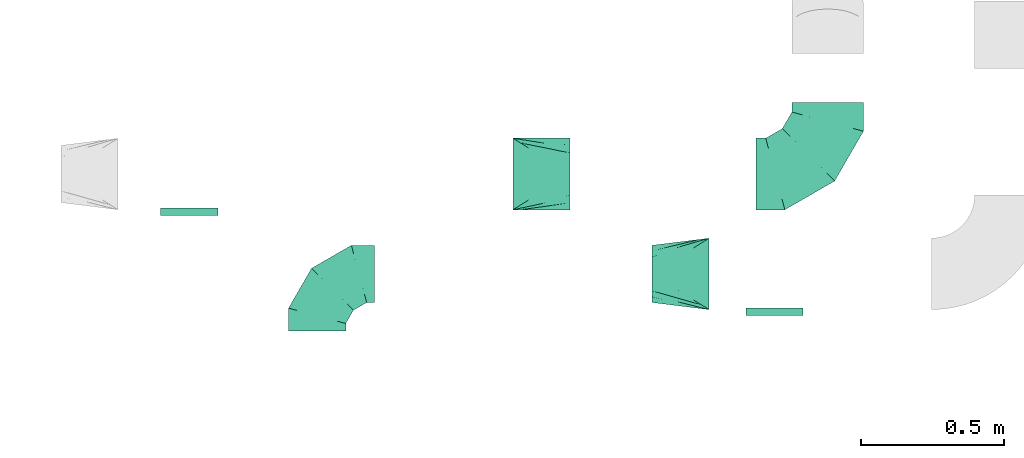
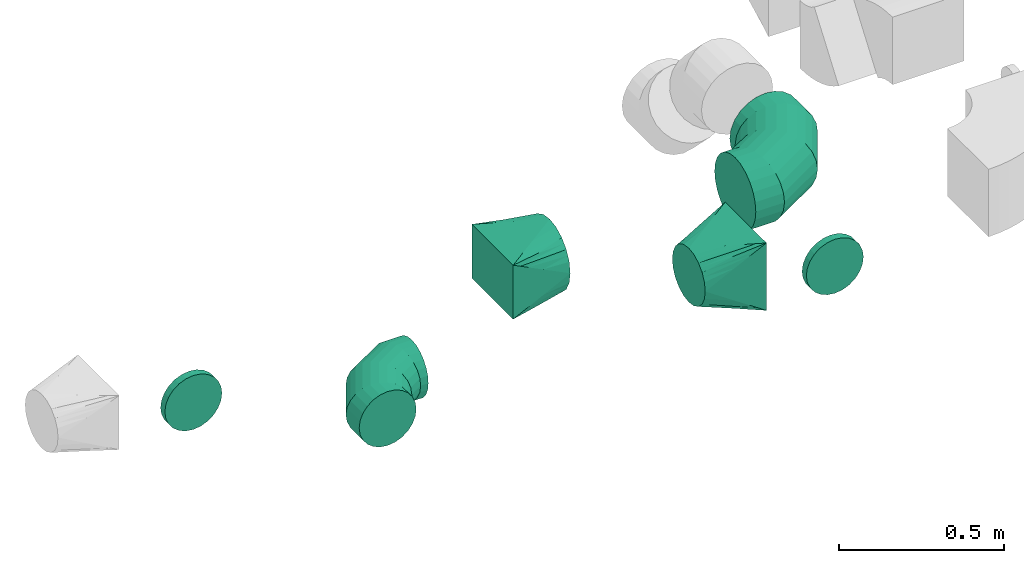
# One storey, part 8 of 44: 6 flow fittings.
"""IFC2X3 building model written with IfcOpenShell, lengths in millimetres."""

import ifcopenshell
import ifcopenshell.guid

model = None  # the IFC model being written
_history = None  # IfcOwnerHistory: only IFC2X3 demands one
_inside = {}  # id of a spatial element -> (the spatial element, [elements in it])
_under = {}  # id of a project, library or spatial element -> (it, [spatial elements below it])
_declared = {}  # id of a project -> (the project, [libraries it declares])
_typed = {}  # id of a type object -> (the type object, [elements of that type])
_made_of = {}  # id of a material, layer set ... -> (it, [elements and type objects made of it])


def new_model(schema):
    """Start an empty IFC model of exactly this schema.

    Asked for "IFC4X3", IfcOpenShell would pick the latest addendum, in which some entities
    have other attributes; the version numbers below select the first issue.
    IFC2X3 requires an IfcOwnerHistory on every rooted entity: one is made here for all.
    """
    global model, _history
    if schema == "IFC4X3":
        model = ifcopenshell.file(schema_version=(4, 3, 0, 0))
    else:
        model = ifcopenshell.file(schema=schema)
    _inside.clear()
    _under.clear()
    _declared.clear()
    _typed.clear()
    _made_of.clear()
    _history = None
    if model.schema == "IFC2X3":
        org = make("IfcOrganization", Name="unknown")
        user = make(
            "IfcPersonAndOrganization",
            ThePerson=make("IfcPerson", FamilyName="unknown"),
            TheOrganization=org,
        )
        app = make(
            "IfcApplication",
            ApplicationDeveloper=org,
            Version="unknown",
            ApplicationFullName="unknown",
            ApplicationIdentifier="unknown",
        )
        _history = make(
            "IfcOwnerHistory",
            OwningUser=user,
            OwningApplication=app,
            ChangeAction="ADDED",
            CreationDate=0,
        )
    return model


def make(cls, **values):
    """One entity of the class cls with the attributes given. An attribute that is None is left unset."""
    return model.create_entity(
        cls, **{name: value for name, value in values.items() if value is not None}
    )


def entity(cls, *values):
    """Any entity or typed value of the class cls, its attributes in the order of the schema. None: left unset."""
    e = model.create_entity(cls)
    for i, value in enumerate(values):
        if value is not None:
            e[i] = value
    return e


def rooted(cls, **values):
    """An entity with a GlobalId (a new one), such as an element, a storey or a relation."""
    return make(cls, GlobalId=ifcopenshell.guid.new(), OwnerHistory=_history, **values)


def si_unit(unit_type, name, prefix=None):
    """IfcSIUnit, for example si_unit("LENGTHUNIT", "METRE", prefix="MILLI")."""
    return make("IfcSIUnit", UnitType=unit_type, Prefix=prefix, Name=name)


def converted_unit(unit_type, name, factor, base, dimensions=None, offset=None):
    """IfcConversionBasedUnit, such as the inch: factor (a typed value) times the base unit."""
    return make(
        "IfcConversionBasedUnit"
        if offset is None
        else "IfcConversionBasedUnitWithOffset",
        ConversionOffset=offset,
        Dimensions=None
        if dimensions is None
        else entity("IfcDimensionalExponents", *dimensions),
        UnitType=unit_type,
        Name=name,
        ConversionFactor=make(
            "IfcMeasureWithUnit", ValueComponent=factor, UnitComponent=base
        ),
    )


def derived_unit(unit_type, elements):
    """IfcDerivedUnit: a product of units, each with its exponent."""
    return make(
        "IfcDerivedUnit",
        Elements=[
            make("IfcDerivedUnitElement", Unit=unit, Exponent=power)
            for unit, power in elements
        ],
        UnitType=unit_type,
    )


def assignment(units):
    """IfcUnitAssignment: the units of a project."""
    return None if units is None else make("IfcUnitAssignment", Units=units)


def point(xyz):
    """IfcCartesianPoint."""
    return None if xyz is None else make("IfcCartesianPoint", Coordinates=xyz)


def direction(xyz):
    """IfcDirection."""
    return None if xyz is None else make("IfcDirection", DirectionRatios=xyz)


def frame(location, z_axis=None, x_axis=None):
    """IfcAxis2Placement3D, a coordinate frame: its origin and axes. An axis left out is left unset."""
    return make(
        "IfcAxis2Placement3D",
        Location=point(location),
        Axis=direction(z_axis),
        RefDirection=direction(x_axis),
    )


def origin():
    """The frame at (0, 0, 0) with its axes left unset."""
    return frame((0.0, 0.0, 0.0))


def place(relative_to, where):
    """IfcLocalPlacement: puts the frame where relative to a parent placement (None: the world)."""
    return make(
        "IfcLocalPlacement", PlacementRelTo=relative_to, RelativePlacement=where
    )


def context(
    kind, dimensions, precision=None, world=None, true_north=None, identifier=None
):
    """IfcGeometricRepresentationContext, for example the 3D "Model" context."""
    return make(
        "IfcGeometricRepresentationContext",
        ContextIdentifier=identifier,
        ContextType=kind,
        CoordinateSpaceDimension=dimensions,
        Precision=precision,
        WorldCoordinateSystem=world,
        TrueNorth=true_north,
    )


def subcontext(parent, identifier, kind, view, scale=None):
    """IfcGeometricRepresentationSubContext, for example "Body" below "Model"."""
    return make(
        "IfcGeometricRepresentationSubContext",
        ContextIdentifier=identifier,
        ContextType=kind,
        ParentContext=parent,
        TargetScale=scale,
        TargetView=view,
    )


def project(units=None, contexts=None):
    """IfcProject with its units and contexts."""
    return rooted(
        "IfcProject",
        Name="project",
        RepresentationContexts=contexts,
        UnitsInContext=assignment(units),
    )


def spatial(cls, under=None, at=None, **own):
    """A site, building, storey or space (cls), placed at a placement, below another one or the project."""
    s = rooted(cls, ObjectPlacement=at, **own)
    if under is not None:
        _under.setdefault(under.id(), (under, []))[1].append(s)
    return s


def faces_of(points, faces, orient=None, outer=None):
    """IfcFace entities. A face is a list of loops; a loop is a list of indices into points, from 0.

    orient and outer hold one flag for each loop. By default every Orientation is true, the
    first loop of a face is its IfcFaceOuterBound and the others are IfcFaceBound.
    """
    made = []
    for i, loops in enumerate(faces):
        bounds = []
        for j, loop in enumerate(loops):
            is_outer = j == 0 if outer is None else outer[i][j]
            bounds.append(
                make(
                    "IfcFaceOuterBound" if is_outer else "IfcFaceBound",
                    Bound=make("IfcPolyLoop", Polygon=[points[k] for k in loop]),
                    Orientation=True if orient is None else orient[i][j],
                )
            )
        made.append(make("IfcFace", Bounds=bounds))
    return made


def faceted_brep(points, faces, orient=None, outer=None, voids=None):
    """IfcFacetedBrep: a solid bounded by flat faces; with voids (closed shells), ...WithVoids."""
    shared = [point(p) for p in points]
    hull = make("IfcClosedShell", CfsFaces=faces_of(shared, faces, orient, outer))
    if voids is None:
        return make("IfcFacetedBrep", Outer=hull)
    return make(
        "IfcFacetedBrepWithVoids",
        Outer=hull,
        Voids=[
            make(cls, CfsFaces=faces_of(shared, fs, o, b)) for cls, fs, o, b in voids
        ],
    )


def shape(context_of_items, identifier, shape_type, items):
    """IfcShapeRepresentation: the items that make up one representation, for example the "Body"."""
    return make(
        "IfcShapeRepresentation",
        ContextOfItems=context_of_items,
        RepresentationIdentifier=identifier,
        RepresentationType=shape_type,
        Items=items,
    )


def source(mapping_origin, context_of_items, identifier, shape_type, items):
    """IfcRepresentationMap: a shape defined once, which mapped items show again and again."""
    return make(
        "IfcRepresentationMap",
        MappingOrigin=mapping_origin,
        MappedRepresentation=shape(context_of_items, identifier, shape_type, items),
    )


def transform(
    local_origin,
    x_axis=None,
    y_axis=None,
    z_axis=None,
    scale=None,
    scale2=None,
    scale3=None,
    uniform=True,
):
    """IfcCartesianTransformationOperator3D, or its non-uniform kind. x_axis, y_axis, z_axis: its Axis1, 2, 3."""
    if uniform:
        return make(
            "IfcCartesianTransformationOperator3D",
            Axis1=direction(x_axis),
            Axis2=direction(y_axis),
            LocalOrigin=point(local_origin),
            Scale=scale,
            Axis3=direction(z_axis),
        )
    return make(
        "IfcCartesianTransformationOperator3DnonUniform",
        Axis1=direction(x_axis),
        Axis2=direction(y_axis),
        LocalOrigin=point(local_origin),
        Scale=scale,
        Axis3=direction(z_axis),
        Scale2=scale2,
        Scale3=scale3,
    )


def mapped(mapping_source, mapping_target):
    """IfcMappedItem: shows the shape of a source again, moved by a transform."""
    return make(
        "IfcMappedItem", MappingSource=mapping_source, MappingTarget=mapping_target
    )


def material(Name=None, Category=None):
    """IfcMaterial."""
    return make("IfcMaterial", Name=Name, Category=Category)


def made_of(thing, what):
    """Note that an element or type object is made of a material, layer set ...; save() writes the relation."""
    if what is not None:
        _made_of.setdefault(what.id(), (what, []))[1].append(thing)
    return thing


def type_object(cls, material=None, **own):
    """A type object (cls), such as IfcWallType, which elements share."""
    return made_of(rooted(cls, **own), material)


def type_shapes(of_type, sources):
    """Give a type object the sources (RepresentationMaps) that its elements show as mapped items."""
    of_type.RepresentationMaps = sources


def element(
    cls,
    number,
    at=None,
    inside=None,
    cuts=None,
    type_object=None,
    material=None,
    context=None,
    identifier="Body",
    shape_type=None,
    held_by="IfcProductDefinitionShape",
    body=None,
    shapes=None,
    **own,
):
    """One element of the class cls, such as IfcWall. Its Tag is "e" and its number.

    at: its placement. inside: the storey or other place that contains it. cuts: it is an
    opening in that element (IfcRelVoidsElement). A single representation is given by context,
    identifier, shape_type and body (its items); several are given by shapes. held_by: the class
    of the entity that holds the representations. save() writes the other relations.
    """
    e = rooted(cls, Tag="e%d" % number, ObjectPlacement=at, **own)
    if body is not None:
        shapes = [shape(context, identifier, shape_type, body)]
    if shapes is not None:
        e.Representation = make(held_by, Representations=shapes)
    if inside is not None:
        _inside.setdefault(inside.id(), (inside, []))[1].append(e)
    if cuts is not None:
        rooted(
            "IfcRelVoidsElement", RelatingBuildingElement=cuts, RelatedOpeningElement=e
        )
    if type_object is not None:
        _typed.setdefault(type_object.id(), (type_object, []))[1].append(e)
    return made_of(e, material)


def aggregate(whole, parts):
    """IfcRelAggregates: a whole, such as a stair, and the parts it consists of."""
    return rooted("IfcRelAggregates", RelatingObject=whole, RelatedObjects=parts)


def save(model, path):
    """Write the relations noted so far, then the file.

    IfcRelAggregates (storeys below a building ...), IfcRelContainedInSpatialStructure (elements
    in a storey), IfcRelDefinesByType, IfcRelAssociatesMaterial and IfcRelDeclares: one each for
    every whole, place, type object, material and project.
    """
    for whole, parts in _under.values():
        aggregate(whole, parts)
    for where, things in _inside.values():
        rooted(
            "IfcRelContainedInSpatialStructure",
            RelatedElements=things,
            RelatingStructure=where,
        )
    for kind, things in _typed.values():
        rooted("IfcRelDefinesByType", RelatedObjects=things, RelatingType=kind)
    for what, things in _made_of.values():
        rooted("IfcRelAssociatesMaterial", RelatedObjects=things, RelatingMaterial=what)
    for by, libraries in _declared.values():
        rooted("IfcRelDeclares", RelatingContext=by, RelatedDefinitions=libraries)
    model.write(path)


model = new_model("IFC2X3")

# Units and contexts
model_context = context("Model", 3, precision=0.01, world=origin(), true_north=direction((6.12303176911189e-17, 1.0)))
body_context = subcontext(model_context, "Body", "Model", "MODEL_VIEW")
ifc_project = project(units=[si_unit("LENGTHUNIT", "METRE", prefix="MILLI"), si_unit("AREAUNIT", "SQUARE_METRE"), si_unit("VOLUMEUNIT", "CUBIC_METRE"), converted_unit("PLANEANGLEUNIT", "DEGREE", entity("IfcRatioMeasure", 0.0174532925199433), si_unit("PLANEANGLEUNIT", "RADIAN"), dimensions=[0, 0, 0, 0, 0, 0, 0]), si_unit("MASSUNIT", "GRAM", prefix="KILO"), derived_unit("MASSDENSITYUNIT", [(si_unit("MASSUNIT", "GRAM", prefix="KILO"), 1), (si_unit("LENGTHUNIT", "METRE"), -3)]), derived_unit("MOMENTOFINERTIAUNIT", [(si_unit("LENGTHUNIT", "METRE"), 4)]), si_unit("TIMEUNIT", "SECOND"), si_unit("FREQUENCYUNIT", "HERTZ"), si_unit("THERMODYNAMICTEMPERATUREUNIT", "DEGREE_CELSIUS"), derived_unit("THERMALTRANSMITTANCEUNIT", [(si_unit("MASSUNIT", "GRAM", prefix="KILO"), 1), (si_unit("THERMODYNAMICTEMPERATUREUNIT", "KELVIN"), -1), (si_unit("TIMEUNIT", "SECOND"), -3)]), derived_unit("VOLUMETRICFLOWRATEUNIT", [(si_unit("LENGTHUNIT", "METRE"), 3), (si_unit("TIMEUNIT", "SECOND"), -1)]), derived_unit("MASSFLOWRATEUNIT", [(si_unit("MASSUNIT", "GRAM", prefix="KILO"), 1), (si_unit("TIMEUNIT", "SECOND"), -1)]), derived_unit("ROTATIONALFREQUENCYUNIT", [(si_unit("TIMEUNIT", "SECOND"), -1)]), si_unit("ELECTRICCURRENTUNIT", "AMPERE"), si_unit("ELECTRICVOLTAGEUNIT", "VOLT"), si_unit("POWERUNIT", "WATT"), si_unit("FORCEUNIT", "NEWTON", prefix="KILO"), si_unit("ILLUMINANCEUNIT", "LUX"), si_unit("LUMINOUSFLUXUNIT", "LUMEN"), si_unit("LUMINOUSINTENSITYUNIT", "CANDELA"), derived_unit("USERDEFINED", [(si_unit("MASSUNIT", "GRAM", prefix="KILO"), -1), (si_unit("LENGTHUNIT", "METRE"), -2), (si_unit("TIMEUNIT", "SECOND"), 3), (si_unit("LUMINOUSFLUXUNIT", "LUMEN"), 1)]), derived_unit("LINEARVELOCITYUNIT", [(si_unit("LENGTHUNIT", "METRE"), 1), (si_unit("TIMEUNIT", "SECOND"), -1)]), si_unit("PRESSUREUNIT", "PASCAL"), derived_unit("USERDEFINED", [(si_unit("LENGTHUNIT", "METRE"), -2), (si_unit("MASSUNIT", "GRAM", prefix="KILO"), 1), (si_unit("TIMEUNIT", "SECOND"), -2)]), derived_unit("LINEARFORCEUNIT", [(si_unit("MASSUNIT", "GRAM", prefix="KILO"), 1), (si_unit("LENGTHUNIT", "METRE"), 1), (si_unit("TIMEUNIT", "SECOND"), -2), (si_unit("LENGTHUNIT", "METRE"), -1)]), derived_unit("PLANARFORCEUNIT", [(si_unit("MASSUNIT", "GRAM", prefix="KILO"), 1), (si_unit("LENGTHUNIT", "METRE"), 1), (si_unit("TIMEUNIT", "SECOND"), -2), (si_unit("LENGTHUNIT", "METRE"), -2)])], contexts=[model_context])

# Site, building, storey
site_placement = place(None, origin())
site = spatial("IfcSite", under=ifc_project, at=site_placement, CompositionType="ELEMENT")
building_placement = place(site_placement, origin())
building = spatial("IfcBuilding", under=site, at=building_placement, CompositionType="ELEMENT")
storey_placement = place(building_placement, frame((0.0, 0.0, 15900.0)))
storey = spatial("IfcBuildingStorey", under=building, at=storey_placement, CompositionType="ELEMENT", Elevation=15900.0)

# Flow fittings
ifc_material = material()
duct_fitting_type_1 = type_object("IfcDuctFittingType", PredefinedType="NOTDEFINED", material=ifc_material)
shared_shape_1 = source(origin(), body_context, "Body", "Brep", [
    faceted_brep([(-250.0, 0.0, -125.0), (-250.0, -32.35, -120.74), (-250.0, -62.5, -108.25), (-250.0, -88.39, -88.39), (-250.0, -108.25, -62.5), (-250.0, -120.74, -32.35), (-250.0, -125.0, 0.0), (-250.0, -120.74, 32.35), (-250.0, -108.25, 62.5), (-250.0, -88.39, 88.39), (-250.0, -62.5, 108.25), (-250.0, -32.35, 120.74), (-250.0, 0.0, 125.0), (-250.0, 32.35, 120.74), (-250.0, 62.5, 108.25), (-250.0, 88.39, 88.39), (-250.0, 108.25, 62.5), (-250.0, 120.74, 32.35), (-250.0, 125.0, 0.0), (-250.0, 120.74, -32.35), (-250.0, 108.25, -62.5), (-250.0, 88.39, -88.39), (-250.0, 62.5, -108.25), (-250.0, 32.35, -120.74), (-191.68, 32.35, 120.74), (-199.76, 62.5, 108.25), (-183.01, 0.0, 125.0), (-206.7, 88.39, 88.39), (-215.37, 120.74, 32.35), (-216.51, 125.0, 0.0), (-212.02, 108.25, 62.5), (-212.02, 108.25, -62.5), (-206.7, 88.39, -88.39), (-215.37, 120.74, -32.35), (-191.68, 32.35, -120.74), (-183.01, 0.0, -125.0), (-199.76, 62.5, -108.25), (-174.34, -32.35, -120.74), (-166.27, -62.5, -108.25), (-159.33, -88.39, -88.39), (-154.01, -108.25, -62.5), (-150.66, -120.74, -32.35), (-149.52, -125.0, 0.0), (-150.66, -120.74, 32.35), (-154.01, -108.25, 62.5), (-159.33, -88.39, 88.39), (-166.27, -62.5, 108.25), (-174.34, -32.35, 120.74), (-90.67, 90.67, 120.74), (-112.74, 112.74, 108.25), (-66.99, 66.99, 125.0), (-131.69, 131.69, 88.39), (-146.23, 146.23, 62.5), (-155.38, 155.38, 32.35), (-158.49, 158.49, 0.0), (-155.38, 155.38, -32.35), (-146.23, 146.23, -62.5), (-131.69, 131.69, -88.39), (-90.67, 90.67, -120.74), (-66.99, 66.99, -125.0), (-112.74, 112.74, -108.25), (-43.3, 43.3, -120.74), (-21.23, 21.23, -108.25), (-2.28, 2.28, -88.39), (12.26, -12.26, -62.5), (21.4, -21.4, -32.35), (24.52, -24.52, 0.0), (21.4, -21.4, 32.35), (12.26, -12.26, 62.5), (-2.28, 2.28, 88.39), (-21.23, 21.23, 108.25), (-43.3, 43.3, 120.74), (-32.35, 191.68, 120.74), (-62.5, 199.76, 108.25), (0.0, 183.01, 125.0), (-88.39, 206.7, 88.39), (-108.25, 212.02, 62.5), (-120.74, 215.37, 32.35), (-125.0, 216.51, 0.0), (-120.74, 215.37, -32.35), (-108.25, 212.02, -62.5), (-88.39, 206.7, -88.39), (-32.35, 191.68, -120.74), (0.0, 183.01, -125.0), (-62.5, 199.76, -108.25), (32.35, 174.34, -120.74), (62.5, 166.27, -108.25), (88.39, 159.33, -88.39), (108.25, 154.01, -62.5), (120.74, 150.66, -32.35), (125.0, 149.52, 0.0), (120.74, 150.66, 32.35), (108.25, 154.01, 62.5), (88.39, 159.33, 88.39), (62.5, 166.27, 108.25), (32.35, 174.34, 120.74), (-32.35, 250.0, -120.74), (-62.5, 250.0, -108.25), (-88.39, 250.0, -88.39), (-108.25, 250.0, -62.5), (-120.74, 250.0, -32.35), (-125.0, 250.0, 0.0), (-120.74, 250.0, 32.35), (-108.25, 250.0, 62.5), (-88.39, 250.0, 88.39), (-62.5, 250.0, 108.25), (-32.35, 250.0, 120.74), (0.0, 250.0, 125.0), (32.35, 250.0, 120.74), (62.5, 250.0, 108.25), (88.39, 250.0, 88.39), (108.25, 250.0, 62.5), (120.74, 250.0, 32.35), (125.0, 250.0, 0.0), (120.74, 250.0, -32.35), (108.25, 250.0, -62.5), (88.39, 250.0, -88.39), (62.5, 250.0, -108.25), (32.35, 250.0, -120.74), (0.0, 250.0, -125.0)], [[[0, 1, 2, 3, 4, 5, 6, 7, 8, 9, 10, 11, 12, 13, 14, 15, 16, 17, 18, 19, 20, 21, 22, 23]], [[24, 25, 14, 13]], [[26, 24, 13, 12]], [[14, 25, 27, 15]], [[28, 29, 18, 17]], [[30, 28, 17, 16]], [[15, 27, 30, 16]], [[20, 31, 32, 21]], [[33, 31, 20, 19]], [[18, 29, 33, 19]], [[34, 35, 0, 23]], [[36, 34, 23, 22]], [[21, 32, 36, 22]], [[1, 0, 35, 37]], [[2, 1, 37, 38]], [[38, 39, 3, 2]], [[5, 4, 40, 41]], [[6, 5, 41, 42]], [[39, 40, 4, 3]], [[6, 42, 43, 7]], [[7, 43, 44, 8]], [[8, 44, 45, 9]], [[9, 45, 46, 10]], [[10, 46, 47, 11]], [[26, 12, 11, 47]], [[48, 49, 25, 24]], [[50, 48, 24, 26]], [[27, 25, 49, 51]], [[52, 53, 28, 30]], [[51, 52, 30, 27]], [[29, 28, 53, 54]], [[55, 56, 31, 33]], [[54, 55, 33, 29]], [[32, 31, 56, 57]], [[58, 59, 35, 34]], [[60, 58, 34, 36]], [[57, 60, 36, 32]], [[37, 35, 59, 61]], [[38, 37, 61, 62]], [[39, 38, 62, 63]], [[41, 40, 64, 65]], [[42, 41, 65, 66]], [[63, 64, 40, 39]], [[43, 42, 66, 67]], [[44, 43, 67, 68]], [[68, 69, 45, 44]], [[46, 45, 69, 70]], [[47, 46, 70, 71]], [[26, 47, 71, 50]], [[72, 73, 49, 48]], [[74, 72, 48, 50]], [[51, 49, 73, 75]], [[76, 77, 53, 52]], [[75, 76, 52, 51]], [[54, 53, 77, 78]], [[79, 80, 56, 55]], [[78, 79, 55, 54]], [[57, 56, 80, 81]], [[82, 83, 59, 58]], [[84, 82, 58, 60]], [[81, 84, 60, 57]], [[61, 59, 83, 85]], [[62, 61, 85, 86]], [[63, 62, 86, 87]], [[65, 64, 88, 89]], [[66, 65, 89, 90]], [[87, 88, 64, 63]], [[67, 66, 90, 91]], [[68, 67, 91, 92]], [[92, 93, 69, 68]], [[70, 69, 93, 94]], [[71, 70, 94, 95]], [[50, 71, 95, 74]], [[96, 97, 98, 99, 100, 101, 102, 103, 104, 105, 106, 107, 108, 109, 110, 111, 112, 113, 114, 115, 116, 117, 118, 119]], [[72, 74, 107, 106]], [[73, 72, 106, 105]], [[75, 73, 105, 104]], [[77, 76, 103, 102]], [[78, 77, 102, 101]], [[75, 104, 103, 76]], [[78, 101, 100, 79]], [[79, 100, 99, 80]], [[80, 99, 98, 81]], [[84, 97, 96, 82]], [[82, 96, 119, 83]], [[84, 81, 98, 97]], [[83, 119, 118, 85]], [[85, 118, 117, 86]], [[116, 87, 86, 117]], [[88, 115, 114, 89]], [[89, 114, 113, 90]], [[115, 88, 87, 116]], [[91, 90, 113, 112]], [[92, 91, 112, 111]], [[111, 110, 93, 92]], [[95, 94, 109, 108]], [[74, 95, 108, 107]], [[110, 109, 94, 93]]]),
])
type_shapes(duct_fitting_type_1, [shared_shape_1])
flow_fitting_1_placement = place(storey_placement, frame((19481.36, 4999.06, 3200.0)))
element("IfcFlowFitting", 1, at=flow_fitting_1_placement, inside=storey, type_object=duct_fitting_type_1, material=ifc_material, context=body_context, shape_type="MappedRepresentation", body=[
    mapped(shared_shape_1, transform((0.0, 0.0, 0.0), scale=1.0)),
])
duct_fitting_type_2 = type_object("IfcDuctFittingType", PredefinedType="NOTDEFINED", material=ifc_material)
shared_shape_2 = source(origin(), body_context, "Body", "Brep", [
    faceted_brep([(-200.0, 0.0, -100.0), (-200.0, -25.88, -96.59), (-200.0, -50.0, -86.6), (-200.0, -70.71, -70.71), (-200.0, -86.6, -50.0), (-200.0, -96.59, -25.88), (-200.0, -100.0, 0.0), (-200.0, -96.59, 25.88), (-200.0, -86.6, 50.0), (-200.0, -70.71, 70.71), (-200.0, -50.0, 86.6), (-200.0, -25.88, 96.59), (-200.0, 0.0, 100.0), (-200.0, 25.88, 96.59), (-200.0, 50.0, 86.6), (-200.0, 70.71, 70.71), (-200.0, 86.6, 50.0), (-200.0, 96.59, 25.88), (-200.0, 100.0, 0.0), (-200.0, 96.59, -25.88), (-200.0, 86.6, -50.0), (-200.0, 70.71, -70.71), (-200.0, 50.0, -86.6), (-200.0, 25.88, -96.59), (-153.35, 25.88, 96.59), (-159.81, 50.0, 86.6), (-146.41, 0.0, 100.0), (-165.36, 70.71, 70.71), (-172.29, 96.59, 25.88), (-173.21, 100.0, 0.0), (-169.62, 86.6, 50.0), (-169.62, 86.6, -50.0), (-165.36, 70.71, -70.71), (-172.29, 96.59, -25.88), (-153.35, 25.88, -96.59), (-146.41, 0.0, -100.0), (-159.81, 50.0, -86.6), (-139.48, -25.88, -96.59), (-133.01, -50.0, -86.6), (-127.46, -70.71, -70.71), (-123.21, -86.6, -50.0), (-120.53, -96.59, -25.88), (-119.62, -100.0, 0.0), (-120.53, -96.59, 25.88), (-123.21, -86.6, 50.0), (-127.46, -70.71, 70.71), (-133.01, -50.0, 86.6), (-139.48, -25.88, 96.59), (-72.54, 72.54, 96.59), (-90.19, 90.19, 86.6), (-53.59, 53.59, 100.0), (-105.35, 105.35, 70.71), (-116.99, 116.99, 50.0), (-124.3, 124.3, 25.88), (-126.79, 126.79, 0.0), (-124.3, 124.3, -25.88), (-116.99, 116.99, -50.0), (-105.35, 105.35, -70.71), (-72.54, 72.54, -96.59), (-53.59, 53.59, -100.0), (-90.19, 90.19, -86.6), (-34.64, 34.64, -96.59), (-16.99, 16.99, -86.6), (-1.83, 1.83, -70.71), (9.81, -9.81, -50.0), (17.12, -17.12, -25.88), (19.62, -19.62, 0.0), (17.12, -17.12, 25.88), (9.81, -9.81, 50.0), (-1.83, 1.83, 70.71), (-16.99, 16.99, 86.6), (-34.64, 34.64, 96.59), (-25.88, 153.35, 96.59), (-50.0, 159.81, 86.6), (0.0, 146.41, 100.0), (-70.71, 165.36, 70.71), (-86.6, 169.62, 50.0), (-96.59, 172.29, 25.88), (-100.0, 173.21, 0.0), (-96.59, 172.29, -25.88), (-86.6, 169.62, -50.0), (-70.71, 165.36, -70.71), (-25.88, 153.35, -96.59), (0.0, 146.41, -100.0), (-50.0, 159.81, -86.6), (25.88, 139.48, -96.59), (50.0, 133.01, -86.6), (70.71, 127.46, -70.71), (86.6, 123.21, -50.0), (96.59, 120.53, -25.88), (100.0, 119.62, 0.0), (96.59, 120.53, 25.88), (86.6, 123.21, 50.0), (70.71, 127.46, 70.71), (50.0, 133.01, 86.6), (25.88, 139.48, 96.59), (-25.88, 200.0, -96.59), (-50.0, 200.0, -86.6), (-70.71, 200.0, -70.71), (-86.6, 200.0, -50.0), (-96.59, 200.0, -25.88), (-100.0, 200.0, 0.0), (-96.59, 200.0, 25.88), (-86.6, 200.0, 50.0), (-70.71, 200.0, 70.71), (-50.0, 200.0, 86.6), (-25.88, 200.0, 96.59), (0.0, 200.0, 100.0), (25.88, 200.0, 96.59), (50.0, 200.0, 86.6), (70.71, 200.0, 70.71), (86.6, 200.0, 50.0), (96.59, 200.0, 25.88), (100.0, 200.0, 0.0), (96.59, 200.0, -25.88), (86.6, 200.0, -50.0), (70.71, 200.0, -70.71), (50.0, 200.0, -86.6), (25.88, 200.0, -96.59), (0.0, 200.0, -100.0)], [[[0, 1, 2, 3, 4, 5, 6, 7, 8, 9, 10, 11, 12, 13, 14, 15, 16, 17, 18, 19, 20, 21, 22, 23]], [[24, 25, 14, 13]], [[26, 24, 13, 12]], [[14, 25, 27, 15]], [[28, 29, 18, 17]], [[30, 28, 17, 16]], [[15, 27, 30, 16]], [[20, 31, 32, 21]], [[33, 31, 20, 19]], [[18, 29, 33, 19]], [[34, 35, 0, 23]], [[36, 34, 23, 22]], [[32, 36, 22, 21]], [[1, 0, 35, 37]], [[2, 1, 37, 38]], [[38, 39, 3, 2]], [[5, 4, 40, 41]], [[6, 5, 41, 42]], [[39, 40, 4, 3]], [[6, 42, 43, 7]], [[7, 43, 44, 8]], [[8, 44, 45, 9]], [[9, 45, 46, 10]], [[10, 46, 47, 11]], [[26, 12, 11, 47]], [[48, 49, 25, 24]], [[50, 48, 24, 26]], [[27, 25, 49, 51]], [[52, 53, 28, 30]], [[51, 52, 30, 27]], [[29, 28, 53, 54]], [[55, 56, 31, 33]], [[54, 55, 33, 29]], [[32, 31, 56, 57]], [[58, 59, 35, 34]], [[60, 58, 34, 36]], [[57, 60, 36, 32]], [[37, 35, 59, 61]], [[38, 37, 61, 62]], [[39, 38, 62, 63]], [[41, 40, 64, 65]], [[42, 41, 65, 66]], [[63, 64, 40, 39]], [[43, 42, 66, 67]], [[44, 43, 67, 68]], [[68, 69, 45, 44]], [[46, 45, 69, 70]], [[47, 46, 70, 71]], [[26, 47, 71, 50]], [[72, 73, 49, 48]], [[74, 72, 48, 50]], [[51, 49, 73, 75]], [[76, 77, 53, 52]], [[75, 76, 52, 51]], [[54, 53, 77, 78]], [[79, 80, 56, 55]], [[78, 79, 55, 54]], [[57, 56, 80, 81]], [[82, 83, 59, 58]], [[84, 82, 58, 60]], [[81, 84, 60, 57]], [[61, 59, 83, 85]], [[62, 61, 85, 86]], [[63, 62, 86, 87]], [[65, 64, 88, 89]], [[66, 65, 89, 90]], [[87, 88, 64, 63]], [[67, 66, 90, 91]], [[68, 67, 91, 92]], [[92, 93, 69, 68]], [[70, 69, 93, 94]], [[71, 70, 94, 95]], [[50, 71, 95, 74]], [[96, 97, 98, 99, 100, 101, 102, 103, 104, 105, 106, 107, 108, 109, 110, 111, 112, 113, 114, 115, 116, 117, 118, 119]], [[72, 74, 107, 106]], [[73, 72, 106, 105]], [[75, 73, 105, 104]], [[102, 101, 78, 77]], [[103, 102, 77, 76]], [[75, 104, 103, 76]], [[78, 101, 100, 79]], [[79, 100, 99, 80]], [[80, 99, 98, 81]], [[84, 97, 96, 82]], [[82, 96, 119, 83]], [[84, 81, 98, 97]], [[118, 117, 86, 85]], [[119, 118, 85, 83]], [[116, 87, 86, 117]], [[88, 115, 114, 89]], [[89, 114, 113, 90]], [[115, 88, 87, 116]], [[91, 90, 113, 112]], [[92, 91, 112, 111]], [[111, 110, 93, 92]], [[95, 94, 109, 108]], [[74, 95, 108, 107]], [[110, 109, 94, 93]]]),
])
type_shapes(duct_fitting_type_2, [shared_shape_2])
flow_fitting_2_placement = place(storey_placement, frame((17696.91, 4649.84, 3229.17), z_axis=(0.0, 0.0, 1.0), x_axis=(-1.0, 0.0, 0.0)))
element("IfcFlowFitting", 2, at=flow_fitting_2_placement, inside=storey, type_object=duct_fitting_type_2, material=ifc_material, context=body_context, shape_type="MappedRepresentation", body=[
    mapped(shared_shape_2, transform((0.0, 0.0, 0.0), scale=1.0)),
])
duct_fitting_type_3 = type_object("IfcDuctFittingType", PredefinedType="NOTDEFINED", material=ifc_material)
shared_shape_3 = source(origin(), body_context, "Body", "Brep", [
    faceted_brep([(200.0, 73.47, 101.13), (200.0, 56.05, 110.0), (200.0, 38.63, 118.88), (200.0, 23.84, 121.22), (200.0, 11.92, 123.11), (200.0, 5.96, 124.06), (200.0, 0.0, 125.0), (200.0, -5.96, 124.06), (200.0, -11.92, 123.11), (200.0, -23.84, 121.22), (200.0, -38.63, 118.88), (200.0, -56.05, 110.0), (200.0, -73.47, 101.13), (200.0, -87.3, 87.3), (200.0, -101.13, 73.47), (200.0, -110.0, 56.05), (200.0, -118.88, 38.63), (200.0, -121.22, 23.84), (200.0, -123.11, 11.92), (200.0, -124.06, 5.96), (200.0, -125.0, 0.0), (200.0, -124.06, -5.96), (200.0, -123.11, -11.92), (200.0, -121.22, -23.84), (200.0, -118.88, -38.63), (200.0, -110.0, -56.05), (200.0, -101.13, -73.47), (200.0, -87.3, -87.3), (200.0, -73.47, -101.13), (200.0, -56.05, -110.0), (200.0, -38.63, -118.88), (200.0, -23.84, -121.22), (200.0, -11.92, -123.11), (200.0, -5.96, -124.06), (200.0, 0.0, -125.0), (200.0, 5.96, -124.06), (200.0, 11.92, -123.11), (200.0, 23.84, -121.22), (200.0, 38.63, -118.88), (200.0, 56.05, -110.0), (200.0, 73.47, -101.13), (200.0, 87.3, -87.3), (200.0, 101.13, -73.47), (200.0, 110.0, -56.05), (200.0, 118.88, -38.63), (200.0, 121.22, -23.84), (200.0, 123.11, -11.92), (200.0, 124.06, -5.96), (200.0, 125.0, 0.0), (200.0, 124.06, 5.96), (200.0, 123.11, 11.92), (200.0, 121.22, 23.84), (200.0, 118.88, 38.63), (200.0, 110.0, 56.05), (200.0, 101.13, 73.47), (200.0, 87.3, 87.3), (0.0, -125.0, 100.0), (0.0, 125.0, 100.0), (0.0, 125.0, -100.0), (0.0, -125.0, -100.0), (104.11, -59.93, 113.01), (100.0, -103.94, 96.79), (26.03, -108.73, 103.25), (78.09, -76.2, 109.76), (52.06, -92.46, 106.51), (188.01, -7.49, 123.5), (176.03, -14.98, 122.0), (152.06, -29.96, 119.01), (128.09, -44.95, 116.01), (52.06, -125.0, 73.97), (78.09, -125.0, 60.96), (104.11, -125.0, 47.94), (128.09, -125.0, 35.96), (152.06, -125.0, 23.97), (176.03, -125.0, 11.99), (188.01, -125.0, 5.99), (26.03, -125.0, 86.99), (26.03, -125.0, -86.99), (52.06, -125.0, -73.97), (78.09, -125.0, -60.96), (104.11, -125.0, -47.94), (128.09, -125.0, -35.96), (152.06, -125.0, -23.97), (176.03, -125.0, -11.99), (188.01, -125.0, -5.99), (100.0, -109.29, -91.44), (52.06, -92.46, -106.51), (78.09, -76.2, -109.76), (104.11, -59.93, -113.01), (128.09, -44.95, -116.01), (152.06, -29.96, -119.01), (176.03, -14.98, -122.0), (188.01, -7.49, -123.5), (26.03, -108.73, -103.25), (26.03, 108.73, -103.25), (52.06, 92.46, -106.51), (78.09, 76.2, -109.76), (104.11, 59.93, -113.01), (128.09, 44.95, -116.01), (152.06, 29.96, -119.01), (176.03, 14.98, -122.0), (188.01, 7.49, -123.5), (100.0, 103.94, -96.79), (52.06, 125.0, -73.97), (78.09, 125.0, -60.96), (104.11, 125.0, -47.94), (128.09, 125.0, -35.96), (152.06, 125.0, -23.97), (176.03, 125.0, -11.99), (188.01, 125.0, -5.99), (26.03, 125.0, -86.99), (26.03, 125.0, 86.99), (52.06, 125.0, 73.97), (78.09, 125.0, 60.96), (104.11, 125.0, 47.94), (128.09, 125.0, 35.96), (152.06, 125.0, 23.97), (176.03, 125.0, 11.99), (188.01, 125.0, 5.99), (100.0, 109.29, 91.44), (52.06, 92.46, 106.51), (78.09, 76.2, 109.76), (104.11, 59.93, 113.01), (128.09, 44.95, 116.01), (152.06, 29.96, 119.01), (176.03, 14.98, 122.0), (188.01, 7.49, 123.5), (26.03, 108.73, 103.25)], [[[0, 1, 2, 3, 4, 5, 6, 7, 8, 9, 10, 11, 12, 13, 14, 15, 16, 17, 18, 19, 20, 21, 22, 23, 24, 25, 26, 27, 28, 29, 30, 31, 32, 33, 34, 35, 36, 37, 38, 39, 40, 41, 42, 43, 44, 45, 46, 47, 48, 49, 50, 51, 52, 53, 54, 55]], [[56, 57, 58, 59]], [[60, 11, 10]], [[56, 61, 62]], [[11, 60, 63, 64]], [[65, 66, 67, 68, 60, 10, 9, 8, 7, 6]], [[62, 61, 12]], [[15, 69, 70, 71]], [[64, 12, 11]], [[16, 71, 72, 73, 74, 75, 20, 19, 18, 17]], [[14, 76, 69]], [[71, 16, 15]], [[61, 76, 13]], [[12, 64, 62]], [[76, 14, 13]], [[12, 61, 13]], [[61, 56, 76]], [[69, 15, 14]], [[75, 74, 73, 72, 71, 70, 69, 76, 56, 59, 77, 78, 79, 80, 81, 82, 83, 84, 20]], [[80, 25, 24]], [[59, 85, 77]], [[25, 80, 79, 78]], [[84, 83, 82, 81, 80, 24, 23, 22, 21, 20]], [[77, 85, 26]], [[29, 86, 87, 88]], [[78, 26, 25]], [[30, 88, 89, 90, 91, 92, 34, 33, 32, 31]], [[28, 93, 86]], [[88, 30, 29]], [[85, 93, 27]], [[26, 78, 77]], [[93, 28, 27]], [[26, 85, 27]], [[85, 59, 93]], [[86, 29, 28]], [[92, 91, 90, 89, 88, 87, 86, 93, 59, 58, 94, 95, 96, 97, 98, 99, 100, 101, 34]], [[97, 39, 38]], [[58, 102, 94]], [[39, 97, 96, 95]], [[101, 100, 99, 98, 97, 38, 37, 36, 35, 34]], [[94, 102, 40]], [[43, 103, 104, 105]], [[95, 40, 39]], [[44, 105, 106, 107, 108, 109, 48, 47, 46, 45]], [[42, 110, 103]], [[105, 44, 43]], [[102, 110, 41]], [[40, 95, 94]], [[110, 42, 41]], [[40, 102, 41]], [[102, 58, 110]], [[103, 43, 42]], [[58, 57, 111, 112, 113, 114, 115, 116, 117, 118, 48, 109, 108, 107, 106, 105, 104, 103, 110]], [[114, 53, 52]], [[57, 119, 111]], [[53, 114, 113, 112]], [[118, 117, 116, 115, 114, 52, 51, 50, 49, 48]], [[111, 119, 54]], [[1, 120, 121, 122]], [[112, 54, 53]], [[2, 122, 123, 124, 125, 126, 6, 5, 4, 3]], [[0, 127, 120]], [[122, 2, 1]], [[119, 127, 55]], [[54, 112, 111]], [[127, 0, 55]], [[54, 119, 55]], [[119, 57, 127]], [[120, 1, 0]], [[57, 56, 62, 64, 63, 60, 68, 67, 66, 65, 6, 126, 125, 124, 123, 122, 121, 120, 127]]]),
])
type_shapes(duct_fitting_type_3, [shared_shape_3])
flow_fitting_3_placement = place(storey_placement, frame((18381.36, 4999.06, 3200.0)))
element("IfcFlowFitting", 3, at=flow_fitting_3_placement, inside=storey, type_object=duct_fitting_type_3, material=ifc_material, context=body_context, shape_type="MappedRepresentation", body=[
    mapped(shared_shape_3, transform((0.0, 0.0, 0.0), scale=1.0)),
])
duct_fitting_type_4 = type_object("IfcDuctFittingType", PredefinedType="NOTDEFINED", material=ifc_material)
shared_shape_4 = source(origin(), body_context, "Body", "Brep", [
    faceted_brep([(20.0, 0.0, -100.0), (20.0, 25.88, -96.59), (20.0, 50.0, -86.6), (20.0, 70.71, -70.71), (20.0, 86.6, -50.0), (20.0, 96.59, -25.88), (20.0, 100.0, 0.0), (20.0, 96.59, 25.88), (20.0, 86.6, 50.0), (20.0, 70.71, 70.71), (20.0, 50.0, 86.6), (20.0, 25.88, 96.59), (20.0, 0.0, 100.0), (20.0, -25.88, 96.59), (20.0, -50.0, 86.6), (20.0, -70.71, 70.71), (20.0, -86.6, 50.0), (20.0, -96.59, 25.88), (20.0, -100.0, 0.0), (20.0, -96.59, -25.88), (20.0, -86.6, -50.0), (20.0, -70.71, -70.71), (20.0, -50.0, -86.6), (20.0, -25.88, -96.59), (0.0, 0.0, 100.0), (-6.1, 0.0, 100.0), (-6.1, -25.88, 96.59), (0.0, -25.88, 96.59), (-6.1, -50.0, 86.6), (0.0, -50.0, 86.6), (0.0, -70.71, 70.71), (-6.1, -70.71, 70.71), (0.0, -86.6, 50.0), (-6.1, -86.6, 50.0), (-6.1, -96.59, 25.88), (0.0, -96.59, 25.88), (-6.1, -100.0, 0.0), (0.0, -100.0, 0.0), (-6.1, -96.59, -25.88), (0.0, -96.59, -25.88), (-6.1, -86.6, -50.0), (0.0, -86.6, -50.0), (0.0, -70.71, -70.71), (-6.1, -70.71, -70.71), (0.0, -50.0, -86.6), (-6.1, -50.0, -86.6), (-6.1, -25.88, -96.59), (0.0, -25.88, -96.59), (-6.1, 0.0, -100.0), (0.0, 0.0, -100.0), (-6.1, 25.88, -96.59), (0.0, 25.88, -96.59), (-6.1, 50.0, -86.6), (0.0, 50.0, -86.6), (0.0, 70.71, -70.71), (-6.1, 70.71, -70.71), (0.0, 86.6, -50.0), (-6.1, 86.6, -50.0), (-6.1, 96.59, -25.88), (0.0, 96.59, -25.88), (-6.1, 100.0, 0.0), (0.0, 100.0, 0.0), (-6.1, 96.59, 25.88), (0.0, 96.59, 25.88), (-6.1, 86.6, 50.0), (0.0, 86.6, 50.0), (0.0, 70.71, 70.71), (-6.1, 70.71, 70.71), (0.0, 50.0, 86.6), (-6.1, 50.0, 86.6), (-6.1, 25.88, 96.59), (0.0, 25.88, 96.59)], [[[0, 1, 2, 3, 4, 5, 6, 7, 8, 9, 10, 11, 12, 13, 14, 15, 16, 17, 18, 19, 20, 21, 22, 23]], [[13, 12, 24, 25, 26, 27]], [[14, 13, 27, 26, 28, 29]], [[30, 15, 14, 29, 28, 31]], [[17, 16, 32, 33, 34, 35]], [[18, 17, 35, 34, 36, 37]], [[32, 16, 15, 30, 31, 33]], [[19, 18, 37, 36, 38, 39]], [[20, 19, 39, 38, 40, 41]], [[42, 21, 20, 41, 40, 43]], [[23, 22, 44, 45, 46, 47]], [[0, 23, 47, 46, 48, 49]], [[44, 22, 21, 42, 43, 45]], [[1, 0, 49, 48, 50, 51]], [[2, 1, 51, 50, 52, 53]], [[54, 3, 2, 53, 52, 55]], [[5, 4, 56, 57, 58, 59]], [[6, 5, 59, 58, 60, 61]], [[56, 4, 3, 54, 55, 57]], [[7, 6, 61, 60, 62, 63]], [[8, 7, 63, 62, 64, 65]], [[66, 9, 8, 65, 64, 67]], [[11, 10, 68, 69, 70, 71]], [[12, 11, 71, 70, 25, 24]], [[68, 10, 9, 66, 67, 69]], [[46, 45, 43, 40, 38, 36, 34, 33, 31, 28, 26, 25, 70, 69, 67, 64, 62, 60, 58, 57, 55, 52, 50, 48]]]),
])
type_shapes(duct_fitting_type_4, [shared_shape_4])
for number, where, z_axis, x_axis in (
    (4, (19295.2, 4524.84, 3200.0), (0.0, 0.0, -1.0), (0.0, -1.0, 0.0)),
    (5, (17249.65, 4874.06, 3200.0), (0.0, 0.0, -1.0), (0.0, -1.0, 0.0)),
):
    element("IfcFlowFitting", number, at=place(storey_placement, frame(where, z_axis=z_axis, x_axis=x_axis)), inside=storey, type_object=duct_fitting_type_4, material=ifc_material, context=body_context, shape_type="MappedRepresentation", body=[
        mapped(shared_shape_4, transform((0.0, 0.0, 0.0), scale=1.0)),
    ])
duct_fitting_type_5 = type_object("IfcDuctFittingType", PredefinedType="NOTDEFINED", material=ifc_material)
shared_shape_5 = source(origin(), body_context, "Body", "Brep", [
    faceted_brep([(200.0, 30.9, 95.11), (200.0, 19.08, 96.98), (200.0, 9.54, 98.49), (200.0, 4.77, 99.24), (200.0, 0.0, 100.0), (200.0, -4.77, 99.24), (200.0, -9.54, 98.49), (200.0, -19.08, 96.98), (200.0, -30.9, 95.11), (200.0, -44.84, 88.0), (200.0, -58.78, 80.9), (200.0, -69.84, 69.84), (200.0, -80.9, 58.78), (200.0, -88.0, 44.84), (200.0, -95.11, 30.9), (200.0, -96.98, 19.08), (200.0, -98.49, 9.54), (200.0, -99.24, 4.77), (200.0, -100.0, 0.0), (200.0, -99.24, -4.77), (200.0, -98.49, -9.54), (200.0, -96.98, -19.08), (200.0, -95.11, -30.9), (200.0, -88.0, -44.84), (200.0, -80.9, -58.78), (200.0, -69.84, -69.84), (200.0, -58.78, -80.9), (200.0, -44.84, -88.0), (200.0, -30.9, -95.11), (200.0, -19.08, -96.98), (200.0, -9.54, -98.49), (200.0, -4.77, -99.24), (200.0, 0.0, -100.0), (200.0, 4.77, -99.24), (200.0, 9.54, -98.49), (200.0, 19.08, -96.98), (200.0, 30.9, -95.11), (200.0, 44.84, -88.0), (200.0, 58.78, -80.9), (200.0, 69.84, -69.84), (200.0, 80.9, -58.78), (200.0, 88.0, -44.84), (200.0, 95.11, -30.9), (200.0, 96.98, -19.08), (200.0, 98.49, -9.54), (200.0, 99.24, -4.77), (200.0, 100.0, 0.0), (200.0, 99.24, 4.77), (200.0, 98.49, 9.54), (200.0, 96.98, 19.08), (200.0, 95.11, 30.9), (200.0, 88.0, 44.84), (200.0, 80.9, 58.78), (200.0, 69.84, 69.84), (200.0, 58.78, 80.9), (200.0, 44.84, 88.0), (0.0, -125.0, 125.0), (0.0, 125.0, 125.0), (0.0, 125.0, -125.0), (0.0, -125.0, -125.0), (104.11, -59.93, 111.99), (100.0, -95.65, 99.93), (26.03, -108.73, 121.75), (78.09, -76.2, 115.24), (52.06, -92.46, 118.49), (188.01, -7.49, 101.5), (176.03, -14.98, 103.0), (152.06, -29.96, 105.99), (128.09, -44.95, 108.99), (52.06, -118.49, 92.46), (78.09, -115.24, 76.2), (104.11, -111.99, 59.93), (128.09, -108.99, 44.95), (152.06, -105.99, 29.96), (176.03, -103.0, 14.98), (188.01, -101.5, 7.49), (26.03, -121.75, 108.73), (26.03, -121.75, -108.73), (52.06, -118.49, -92.46), (78.09, -115.24, -76.2), (104.11, -111.99, -59.93), (128.09, -108.99, -44.95), (152.06, -105.99, -29.96), (176.03, -103.0, -14.98), (188.01, -101.5, -7.49), (100.0, -99.93, -95.65), (52.06, -92.46, -118.49), (78.09, -76.2, -115.24), (104.11, -59.93, -111.99), (128.09, -44.95, -108.99), (152.06, -29.96, -105.99), (176.03, -14.98, -103.0), (188.01, -7.49, -101.5), (26.03, -108.73, -121.75), (26.03, 108.73, -121.75), (52.06, 92.46, -118.49), (78.09, 76.2, -115.24), (104.11, 59.93, -111.99), (128.09, 44.95, -108.99), (152.06, 29.96, -105.99), (176.03, 14.98, -103.0), (188.01, 7.49, -101.5), (100.0, 95.65, -99.93), (52.06, 118.49, -92.46), (78.09, 115.24, -76.2), (104.11, 111.99, -59.93), (128.09, 108.99, -44.95), (152.06, 105.99, -29.96), (176.03, 103.0, -14.98), (188.01, 101.5, -7.49), (26.03, 121.75, -108.73), (26.03, 121.75, 108.73), (52.06, 118.49, 92.46), (78.09, 115.24, 76.2), (104.11, 111.99, 59.93), (128.09, 108.99, 44.95), (152.06, 105.99, 29.96), (176.03, 103.0, 14.98), (188.01, 101.5, 7.49), (100.0, 99.93, 95.65), (52.06, 92.46, 118.49), (78.09, 76.2, 115.24), (104.11, 59.93, 111.99), (128.09, 44.95, 108.99), (152.06, 29.96, 105.99), (176.03, 14.98, 103.0), (188.01, 7.49, 101.5), (26.03, 108.73, 121.75)], [[[0, 1, 2, 3, 4, 5, 6, 7, 8, 9, 10, 11, 12, 13, 14, 15, 16, 17, 18, 19, 20, 21, 22, 23, 24, 25, 26, 27, 28, 29, 30, 31, 32, 33, 34, 35, 36, 37, 38, 39, 40, 41, 42, 43, 44, 45, 46, 47, 48, 49, 50, 51, 52, 53, 54, 55]], [[56, 57, 58, 59]], [[60, 9, 8]], [[56, 61, 62]], [[9, 60, 63, 64]], [[65, 66, 67, 68, 60, 8, 7, 6, 5, 4]], [[62, 61, 10]], [[13, 69, 70, 71]], [[64, 10, 9]], [[14, 71, 72, 73, 74, 75, 18, 17, 16, 15]], [[12, 76, 69]], [[71, 14, 13]], [[61, 76, 11]], [[10, 64, 62]], [[76, 12, 11]], [[10, 61, 11]], [[61, 56, 76]], [[69, 13, 12]], [[75, 74, 73, 72, 71, 70, 69, 76, 56, 59, 77, 78, 79, 80, 81, 82, 83, 84, 18]], [[80, 23, 22]], [[59, 85, 77]], [[23, 80, 79, 78]], [[84, 83, 82, 81, 80, 22, 21, 20, 19, 18]], [[77, 85, 24]], [[27, 86, 87, 88]], [[78, 24, 23]], [[28, 88, 89, 90, 91, 92, 32, 31, 30, 29]], [[26, 93, 86]], [[88, 28, 27]], [[85, 93, 25]], [[24, 78, 77]], [[93, 26, 25]], [[24, 85, 25]], [[85, 59, 93]], [[86, 27, 26]], [[92, 91, 90, 89, 88, 87, 86, 93, 59, 58, 94, 95, 96, 97, 98, 99, 100, 101, 32]], [[97, 37, 36]], [[58, 102, 94]], [[37, 97, 96, 95]], [[101, 100, 99, 98, 97, 36, 35, 34, 33, 32]], [[94, 102, 38]], [[41, 103, 104, 105]], [[95, 38, 37]], [[42, 105, 106, 107, 108, 109, 46, 45, 44, 43]], [[40, 110, 103]], [[105, 42, 41]], [[102, 110, 39]], [[38, 95, 94]], [[110, 40, 39]], [[38, 102, 39]], [[102, 58, 110]], [[103, 41, 40]], [[58, 57, 111, 112, 113, 114, 115, 116, 117, 118, 46, 109, 108, 107, 106, 105, 104, 103, 110]], [[114, 51, 50]], [[57, 119, 111]], [[51, 114, 113, 112]], [[118, 117, 116, 115, 114, 50, 49, 48, 47, 46]], [[111, 119, 52]], [[55, 120, 121, 122]], [[112, 52, 51]], [[0, 122, 123, 124, 125, 126, 4, 3, 2, 1]], [[54, 127, 120]], [[122, 0, 55]], [[119, 127, 53]], [[52, 112, 111]], [[127, 54, 53]], [[52, 119, 53]], [[119, 57, 127]], [[120, 55, 54]], [[57, 56, 62, 64, 63, 60, 68, 67, 66, 65, 4, 126, 125, 124, 123, 122, 121, 120, 127]]]),
])
type_shapes(duct_fitting_type_5, [shared_shape_5])
flow_fitting_4_placement = place(storey_placement, frame((19067.05, 4649.84, 3229.17), z_axis=(0.0, 0.0, 1.0), x_axis=(-1.0, 0.0, 0.0)))
element("IfcFlowFitting", 6, at=flow_fitting_4_placement, inside=storey, type_object=duct_fitting_type_5, material=ifc_material, context=body_context, shape_type="MappedRepresentation", body=[
    mapped(shared_shape_5, transform((0.0, 0.0, 0.0), scale=1.0)),
])

save(model, "model.ifc")
